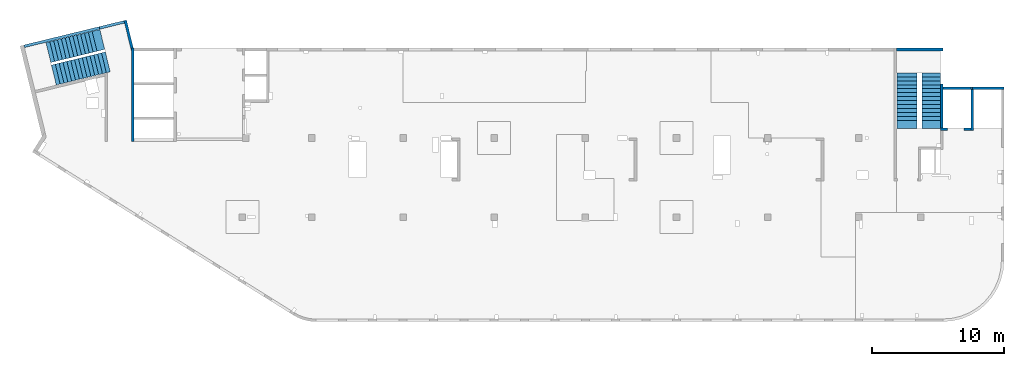
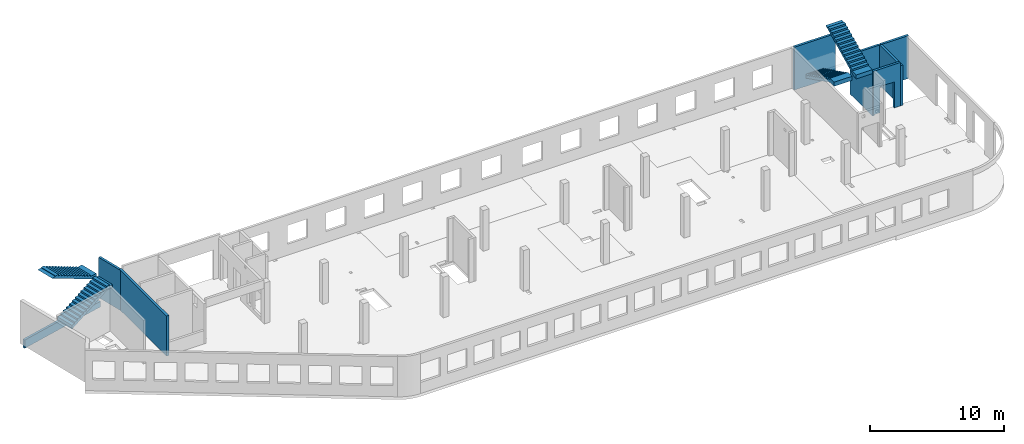
# One storey, part 3 of 6: 9 walls, 4 stairs, 3 openings.
"""IFC4 building model written with IfcOpenShell, lengths in millimetres."""

from ifc_helpers import new_model, entity, si_unit, converted_unit, derived_unit, direction, frame, origin, place, context, subcontext, project, spatial, indexed_curve, outline, extrude, polygons, material, type_object, element, save


model = new_model("IFC4")

# Units and contexts
model_context = context("Model", 3, precision=0.01, world=origin(), true_north=direction((6.12303176911189e-17, 1.0)))
plan_context = context("Plan", 3, precision=0.01, world=origin(), true_north=direction((6.12303176911189e-17, 1.0)))
body_context = subcontext(model_context, "Body", "Model", "MODEL_VIEW")
ifc_project = project(units=[si_unit("LENGTHUNIT", "METRE", prefix="MILLI"), si_unit("AREAUNIT", "SQUARE_METRE"), si_unit("VOLUMEUNIT", "CUBIC_METRE"), converted_unit("PLANEANGLEUNIT", "DEGREE", entity("IfcRatioMeasure", 0.0174532925199433), si_unit("PLANEANGLEUNIT", "RADIAN"), dimensions=[0, 0, 0, 0, 0, 0, 0]), si_unit("MASSUNIT", "GRAM", prefix="KILO"), derived_unit("MASSDENSITYUNIT", [(si_unit("MASSUNIT", "GRAM", prefix="KILO"), 1), (si_unit("LENGTHUNIT", "METRE"), -3)]), derived_unit("MOMENTOFINERTIAUNIT", [(si_unit("LENGTHUNIT", "METRE"), 4)]), si_unit("TIMEUNIT", "SECOND"), si_unit("FREQUENCYUNIT", "HERTZ"), si_unit("THERMODYNAMICTEMPERATUREUNIT", "DEGREE_CELSIUS"), derived_unit("THERMALTRANSMITTANCEUNIT", [(si_unit("MASSUNIT", "GRAM", prefix="KILO"), 1), (si_unit("THERMODYNAMICTEMPERATUREUNIT", "KELVIN"), -1), (si_unit("TIMEUNIT", "SECOND"), -3)]), derived_unit("VOLUMETRICFLOWRATEUNIT", [(si_unit("LENGTHUNIT", "METRE"), 3), (si_unit("TIMEUNIT", "SECOND"), -1)]), derived_unit("MASSFLOWRATEUNIT", [(si_unit("MASSUNIT", "GRAM", prefix="KILO"), 1), (si_unit("TIMEUNIT", "SECOND"), -1)]), derived_unit("ROTATIONALFREQUENCYUNIT", [(si_unit("TIMEUNIT", "SECOND"), -1)]), si_unit("ELECTRICCURRENTUNIT", "AMPERE"), si_unit("ELECTRICVOLTAGEUNIT", "VOLT"), si_unit("POWERUNIT", "WATT"), si_unit("FORCEUNIT", "NEWTON", prefix="KILO"), si_unit("ILLUMINANCEUNIT", "LUX"), si_unit("LUMINOUSFLUXUNIT", "LUMEN"), si_unit("LUMINOUSINTENSITYUNIT", "CANDELA"), derived_unit("USERDEFINED", [(si_unit("MASSUNIT", "GRAM", prefix="KILO"), -1), (si_unit("LENGTHUNIT", "METRE"), -2), (si_unit("TIMEUNIT", "SECOND"), 3), (si_unit("LUMINOUSFLUXUNIT", "LUMEN"), 1)]), derived_unit("LINEARVELOCITYUNIT", [(si_unit("LENGTHUNIT", "METRE"), 1), (si_unit("TIMEUNIT", "SECOND"), -1)]), si_unit("PRESSUREUNIT", "PASCAL"), derived_unit("USERDEFINED", [(si_unit("LENGTHUNIT", "METRE"), -2), (si_unit("MASSUNIT", "GRAM", prefix="KILO"), 1), (si_unit("TIMEUNIT", "SECOND"), -2)]), derived_unit("LINEARFORCEUNIT", [(si_unit("MASSUNIT", "GRAM", prefix="KILO"), 1), (si_unit("LENGTHUNIT", "METRE"), 1), (si_unit("TIMEUNIT", "SECOND"), -2), (si_unit("LENGTHUNIT", "METRE"), -1)]), derived_unit("PLANARFORCEUNIT", [(si_unit("MASSUNIT", "GRAM", prefix="KILO"), 1), (si_unit("LENGTHUNIT", "METRE"), 1), (si_unit("TIMEUNIT", "SECOND"), -2), (si_unit("LENGTHUNIT", "METRE"), -2)])], contexts=[model_context, plan_context])

# Site, building, storey
site_placement = place(None, origin())
site = spatial("IfcSite", under=ifc_project, at=site_placement, CompositionType="ELEMENT")
building_placement = place(site_placement, origin())
building = spatial("IfcBuilding", under=site, at=building_placement, CompositionType="ELEMENT")
storey_placement = place(building_placement, frame((0.0, 0.0, 8100.0)))
storey = spatial("IfcBuildingStorey", under=building, at=storey_placement, Name="03", CompositionType="ELEMENT", Elevation=8100.0)

# Walls
ifc_material_1 = material()
wall_type = type_object("IfcWallType", Name=":ADSK_ 25_200", PredefinedType="STANDARD")
wall_1_placement = place(storey_placement, frame((71070.0, 17470.0, -400.0)))
element("IfcWall", 1, at=wall_1_placement, inside=storey, type_object=wall_type, material=ifc_material_1, Name=":ADSK_ 25_200", ObjectType=":ADSK_ 25_200", PredefinedType="NOTDEFINED", context=body_context, shape_type="SweptSolid", body=[
    extrude(outline(indexed_curve([(2500.0008178711, -99.9999999999999), (2500.0008178711, 100.0), (99.9999999999943, 99.9999999999992), (99.9999999999949, -100.000000000001), (2500.0008178711, -99.9999999999999)], self_intersect=False)), origin(), (0.0, 0.0, 1.0), 3900.0),
])
wall_2_placement = place(storey_placement, frame((71170.0, 17370.0, -150.0), z_axis=(0.0, 0.0, 1.0), x_axis=(0.0, -1.0, 0.0)))
element("IfcWall", 2, at=wall_2_placement, inside=storey, type_object=wall_type, material=ifc_material_1, Name=":ADSK_ 25_200", ObjectType=":ADSK_ 25_200", PredefinedType="NOTDEFINED", context=body_context, shape_type="SweptSolid", body=[
    extrude(outline(indexed_curve([(3100.0, 100.000000000003), (-2.79449581754433e-13, 100.000000000003), (2.79449581754433e-13, -100.000000000003), (3100.0, -100.000000000003), (3100.0, 100.000000000003)], self_intersect=False)), origin(), (0.0, 0.0, 1.0), 3650.0),
])

# Wall, opening
wall_3_placement = place(storey_placement, frame((71070.0, 14370.0, -150.0), z_axis=(0.0, 0.0, 1.0), x_axis=(-1.0, 0.0, 0.0)))
wall_3 = element("IfcWall", 3, at=wall_3_placement, inside=storey, type_object=wall_type, material=ifc_material_1, Name=":ADSK_ 25_200", ObjectType=":ADSK_ 25_200", PredefinedType="NOTDEFINED", context=body_context, shape_type="Tessellation", body=[
    polygons([(2299.99918212887, -100.000000000003, 3950.0), (2099.99918212887, -100.000000000001, 3950.0), (-2.4387927500343e-12, -100.000000000001, 3950.0), (-2.4387927500343e-12, -100.000000000001, 0.0), (529.999182128873, -100.000000000001, 0.0), (529.999182128864, -100.000000000001, 2369.99999999805), (1769.99918212887, -99.9999999999989, 2369.99999999804), (1769.99918212887, -99.9999999999989, 0.0), (2299.99918212887, -100.000000000003, 0.0), (2299.99918212887, -100.000000000001, 3650.0), (-3.00376710535355e-12, 99.9999999999968, 3950.0), (2099.99918212887, 99.9999999999989, 3950.0), (2299.99918212887, 99.9999999999989, 3950.0), (2299.99918212887, 99.9999999999989, 3900.0), (2299.99918212887, 99.9999999999989, 0.0), (2099.99918212887, 99.9999999999989, 0.0), (1769.99918212887, 99.9999999999989, 0.0), (1769.99918212887, 99.9999999999989, 2369.99999999805), (529.999182128872, 99.9999999999989, 2369.99999999805), (529.999182128872, 99.9999999999989, 0.0), (-3.00376710535355e-12, 99.9999999999968, 0.0), (-3.00376710535355e-12, 99.9999999999989, 3650.0)], [[[1, 2, 3, 4, 5, 6, 7, 8, 9, 10]], [[11, 12, 13, 14, 15, 16, 17, 18, 19, 20, 21, 22]], [[4, 21, 20, 5]], [[3, 2, 1, 13, 12, 11]], [[4, 3, 11, 22, 21]], [[6, 19, 18, 7]], [[7, 18, 17, 8]], [[19, 6, 5, 20]], [[9, 15, 14, 13, 1, 10]], [[15, 9, 8, 17, 16]]], closed=True),
])
opening_1_placement = place(wall_3_placement, frame((71070.0, 14370.0, 150.0), z_axis=(0.0, 0.0, 1.0), x_axis=(-1.0, 0.0, 0.0)))
element("IfcOpeningElement", 4, at=opening_1_placement, cuts=wall_3, Name=":ADSK_ 25_200", PredefinedType="OPENING", context=body_context, shape_type="SweptSolid", body=[
    extrude(outline(indexed_curve([(-619.999999999998, -1184.99999999902), (620.000000000006, -1184.99999999902), (620.000000000006, 1184.99999999902), (-619.999999999998, 1184.99999999902), (-619.999999999998, -1184.99999999902)], self_intersect=False)), frame((69920.0, 14570.0, 1035.0), z_axis=(0.0, -1.0, 0.0), x_axis=(-1.0, 0.0, 0.0)), (0.0, 0.0, 1.0), 400.000000001943),
])

# Wall, openings
wall_4_placement = place(storey_placement, frame((7600.0, 20500.0, -150.0), z_axis=(0.0, 0.0, 1.0), x_axis=(0.0, -1.0, 0.0)))
wall_4 = element("IfcWall", 5, at=wall_4_placement, inside=storey, type_object=wall_type, material=ifc_material_1, Name=":ADSK_ 25_200", ObjectType=":ADSK_ 25_200", PredefinedType="NOTDEFINED", context=body_context, shape_type="Tessellation", body=[
    polygons([(0.0, -100.000000000001, 0.0), (226.50010582161, -99.9999999999996, 0.0), (7050.0006393668, -99.9999999999996, 0.0), (7050.0006393668, -99.9999999999996, 3650.0), (226.500105821614, -99.9999999999996, 3650.0), (0.0, -100.000000000001, 3650.0), (0.0, 100.0, 0.0), (0.0, 100.0, 3650.0), (200.000000000002, 100.0, 3650.0), (6850.0006393668, 100.0, 3650.0), (7050.0006393668, 99.9999999999993, 3650.0), (7050.0006393668, 100.0, 1200.0), (7050.0006393668, 99.9999999999993, 0.0), (6850.0006393668, 100.0, 0.0), (0.0, 50.6443876577722, 0.0), (0.0, 50.6443876577722, 3650.0), (0.0, 7.9044633377313e-14, 3650.0)], [[[1, 2, 3, 4, 5, 6]], [[7, 8, 9, 10, 11, 12, 13, 14]], [[3, 2, 1, 15, 7, 14, 13]], [[6, 5, 4, 11, 10, 9, 8, 16, 17]], [[1, 6, 17, 16, 8, 7, 15]], [[4, 3, 13, 12, 11]]], closed=True),
])
placement_1 = place(wall_4_placement, frame((20500.0, -7600.0, 150.0), z_axis=(0.0, 0.0, 1.0), x_axis=(0.0, 1.0, 0.0)))
element("IfcOpeningElement", 6, at=placement_1, cuts=wall_4, Name=":ADSK_ 25_200", PredefinedType="OPENING", context=body_context, shape_type="SweptSolid", body=[
    extrude(outline(indexed_curve([(-154.999999999993, -154.999999999999), (154.999999999993, -154.999999999999), (154.999999999993, 154.999999999999), (-154.999999999993, 154.999999999999), (-154.999999999993, -154.999999999999)], self_intersect=False)), frame((7500.0, 14360.0, 3655.0), z_axis=(1.0, 0.0, 0.0), x_axis=(0.0, 0.0, -1.0)), (0.0, 0.0, 1.0), 200.000000000962),
])
element("IfcOpeningElement", 7, at=placement_1, cuts=wall_4, Name=":ADSK_ 25_200", PredefinedType="OPENING", context=body_context, shape_type="SweptSolid", body=[
    extrude(outline(indexed_curve([(-154.999999999993, -154.999999999999), (154.999999999993, -154.999999999999), (154.999999999993, 154.999999999999), (-154.999999999993, 154.999999999999), (-154.999999999993, -154.999999999999)], self_intersect=False)), frame((7500.0, 14800.0, 3655.0), z_axis=(1.0, 0.0, 0.0), x_axis=(0.0, 0.0, -1.0)), (0.0, 0.0, 1.0), 200.000000000962),
])

# Walls
wall_5_placement = place(storey_placement, frame((68870.0, 17780.0, -400.0), z_axis=(0.0, 0.0, 1.0), x_axis=(0.0, -1.0, 0.0)))
element("IfcWall", 8, at=wall_5_placement, inside=storey, type_object=wall_type, material=ifc_material_1, Name=":ADSK_ 25_200", ObjectType=":ADSK_ 25_200", PredefinedType="NOTDEFINED", context=body_context, shape_type="Tessellation", body=[
    polygons([(2.16573425859679e-12, -99.9999999999946, 0.0), (3310.0, -99.9999999999946, 0.0), (3310.0, -99.9999999999946, 249.999999999999), (3310.0, -99.9999999999946, 3900.0), (2.16573425859679e-12, -99.9999999999946, 3900.0), (3310.0, 100.000000000012, 0.0), (410.0, 100.000000000003, 0.0), (210.0, 100.000000000003, 0.0), (2.16573425859679e-12, 100.000000000012, 0.0), (2.16573425859679e-12, 100.000000000012, 3900.0), (3310.0, 100.000000000012, 3900.0)], [[[1, 2, 3, 4, 5]], [[6, 7, 8, 9, 10, 11]], [[2, 1, 9, 8, 7, 6]], [[9, 1, 5, 10]], [[2, 6, 11, 4, 3]], [[5, 4, 11, 10]]], closed=True),
])
wall_6_placement = place(storey_placement, frame((68970.0, 17470.0, -400.0)))
element("IfcWall", 9, at=wall_6_placement, inside=storey, type_object=wall_type, material=ifc_material_1, Name=":ADSK_ 25_200", ObjectType=":ADSK_ 25_200", PredefinedType="NOTDEFINED", context=body_context, shape_type="Tessellation", body=[
    polygons([(6.89939203009021e-12, -100.000000000001, 0.0), (2199.99918212887, -100.000000000001, 0.0), (2199.99918212887, -100.000000000001, 249.999999999999), (2099.99918212888, -100.000000000001, 249.999999999999), (2099.99918212888, -100.000000000001, 3900.0), (6.89939203009021e-12, -100.000000000001, 3900.0), (2199.99918212887, 99.9999999999989, 0.0), (6.28061057235613e-12, 99.9999999999989, 0.0), (6.28061057235613e-12, 99.9999999999989, 3900.0), (2099.99918212888, 99.9999999999989, 3900.0), (2099.99918212888, 99.9999999999989, 249.999999999999), (2199.99918212887, 99.9999999999989, 249.999999999999)], [[[1, 2, 3, 4, 5, 6]], [[7, 8, 9, 10, 11, 12]], [[2, 1, 8, 7]], [[2, 7, 12, 3]], [[5, 4, 11, 10]], [[8, 1, 6, 9]], [[4, 3, 12, 11]], [[6, 5, 10, 9]]], closed=True),
])
wall_7_placement = place(storey_placement, frame((65430.0, 20400.0, -400.0)))
element("IfcWall", 10, at=wall_7_placement, inside=storey, type_object=wall_type, material=ifc_material_1, Name=":ADSK_ 25_200", ObjectType=":ADSK_ 25_200", PredefinedType="NOTDEFINED", context=body_context, shape_type="SweptSolid", body=[
    extrude(outline(indexed_curve([(3539.99999999995, 99.9999999999989), (-3.67073603151997e-13, 99.9999999999989), (3.67073603151997e-13, -99.9999999999989), (3539.99999999995, -99.9999999999989), (3539.99999999995, 99.9999999999989)], self_intersect=False)), origin(), (0.0, 0.0, 1.0), 3900.0),
])
wall_8_placement = place(storey_placement, frame((7033.44, 22609.75, -150.0), z_axis=(0.0, 0.0, 1.0), x_axis=(0.236826092990328, -0.971552058141475, 0.0)))
element("IfcWall", 11, at=wall_8_placement, inside=storey, type_object=wall_type, material=ifc_material_1, Name=":ADSK_ 25_200", ObjectType=":ADSK_ 25_200", PredefinedType="NOTDEFINED", context=body_context, shape_type="Tessellation", body=[
    polygons([(-4.33146851719357e-12, -99.9999999999989, 0.0), (2380.28371765147, -99.9999999999995, 0.0), (2380.28371765147, -100.000000000001, 3650.0), (199.999999999998, -100.0, 3650.0), (-4.33146851719357e-12, -99.9999999999989, 3650.0), (-4.33146851719357e-12, -99.9999999999989, 3150.0), (-4.33146851719357e-12, 100.0, 0.0), (-4.33146851719357e-12, 100.0, 3650.0), (2195.90359543113, 99.9999999999989, 3650.0), (2195.90359543113, 99.9999999999989, 0.0), (2160.22707367122, -46.3588648763722, 0.0), (2160.22707367122, -46.3588648763722, 3650.0)], [[[1, 2, 3, 4, 5, 6]], [[7, 8, 9, 10]], [[2, 1, 7, 10, 11]], [[11, 10, 9, 12]], [[1, 6, 5, 8, 7]], [[3, 2, 11, 12]], [[5, 4, 3, 12, 9, 8]]], closed=True),
])
wall_9_placement = place(storey_placement, frame((-618.13, 20641.67, -900.0), z_axis=(0.0, 0.0, 1.0), x_axis=(0.971552058141473, 0.236826092990338, 0.0)))
element("IfcWall", 12, at=wall_9_placement, inside=storey, type_object=wall_type, material=ifc_material_1, Name=":ADSK_ 25_200", ObjectType=":ADSK_ 25_200", PredefinedType="NOTDEFINED", context=body_context, shape_type="Tessellation", body=[
    polygons([(0.0, -100.000000000003, -1.08286712929839e-12), (7799.99206966279, -99.9999999999989, -1.08286712929839e-12), (7799.99206966279, -99.9999999999989, 500.000000000004), (5869.9920696628, -100.000000000003, 500.000000000004), (5869.99206966279, -100.000000000003, 750.000000000001), (5.41433564649196e-13, -100.000000000003, 750.000000000001), (7799.99206966279, 99.9999999999989, -1.08286712929839e-12), (1.08286712929839e-12, 99.9999999999989, -1.08286712929839e-12), (0.0, 99.9999999999989, 500.000000000001), (0.0, 99.9999999999989, 750.000000000001), (5869.9920696628, 99.9999999999989, 750.000000000001), (5869.9920696628, 99.9999999999989, 500.000000000004), (7799.99206966279, 99.9999999999989, 500.000000000004)], [[[1, 2, 3, 4, 5, 6]], [[7, 8, 9, 10, 11, 12, 13]], [[2, 1, 8, 7]], [[10, 6, 5, 11]], [[12, 4, 3, 13]], [[4, 12, 11, 5]], [[2, 7, 13, 3]], [[1, 6, 10, 9, 8]]], closed=True),
])

# Stairs
ifc_material_2 = material()
stair_type_1 = type_object("IfcStairType", Name="18: 15", PredefinedType="HALF_TURN_STAIR")
placement_2 = place(storey_placement, origin())
element("IfcStair", 13, at=placement_2, inside=storey, type_object=stair_type_1, material=ifc_material_2, Name="18: 15", ObjectType="18: 15", PredefinedType="HALF_TURN_STAIR", context=body_context, shape_type="SweptSolid", body=[
    extrude(outline(indexed_curve([(843.870967741944, -2179.17507067743), (1213.87096774194, -2179.17507067743), (1213.87096774195, -1871.96147517747), (-906.129032258053, 2368.03852482254), (-906.129032258053, 2020.82492932259), (-956.129032258054, 2020.82492932259), (-956.129032258054, 1720.82492932259), (-806.129032258056, 1720.82492932259), (-806.129032258056, 1420.82492932259), (-656.129032258055, 1420.82492932259), (-656.129032258055, 1120.82492932258), (-506.129032258057, 1120.82492932258), (-506.129032258057, 820.824929322583), (-356.129032258056, 820.824929322583), (-356.129032258056, 520.824929322582), (-206.129032258056, 520.824929322582), (-206.129032258056, 220.824929322581), (-56.1290322580552, 220.824929322581), (-56.1290322580552, -79.1750706774201), (93.8709677419453, -79.1750706774201), (93.8709677419453, -379.175070677421), (243.870967741946, -379.175070677421), (243.870967741946, -679.175070677422), (393.870967741944, -679.175070677422), (393.870967741944, -979.175070677423), (543.870967741945, -979.175070677423), (543.870967741945, -1279.17507067742), (693.870967741945, -1279.17507067742), (693.870967741945, -1579.17507067743), (843.870967741944, -1579.17507067743), (843.870967741944, -2179.17507067743)], self_intersect=False)), frame((67360.0, 16609.17, 4713.87), z_axis=(1.0, 0.0, 0.0), x_axis=(0.0, 0.0, -1.0)), (0.0, 0.0, 1.0), 1390.0),
])
stair_type_2 = type_object("IfcStairType", Name="24: 22", PredefinedType="HALF_TURN_STAIR")
element("IfcStair", 14, at=placement_2, inside=storey, type_object=stair_type_2, material=ifc_material_2, Name="24: 22", ObjectType="24: 22", PredefinedType="HALF_TURN_STAIR", context=body_context, shape_type="SweptSolid", body=[
    extrude(outline(indexed_curve([(-1961.8142397, -852.000000000003), (-1961.8142397, -1202.0), (-1914.60064420005, -1202.00000000001), (1645.39935579997, 577.999999999996), (2238.18576029999, 577.999999999996), (2238.18576029999, 947.999999999997), (1638.18576030001, 947.999999999997), (1638.18576030001, 797.999999999998), (1338.18576030001, 797.999999999998), (1338.18576030001, 647.999999999998), (1038.18576030001, 647.999999999998), (1038.18576030001, 497.999999999997), (738.185760300008, 497.999999999997), (738.185760300008, 347.999999999997), (438.185760300007, 347.999999999997), (438.185760300007, 197.999999999996), (138.185760300006, 197.999999999996), (138.185760300006, 47.9999999999977), (-161.814239699995, 47.9999999999977), (-161.814239699995, -102.000000000003), (-461.814239699997, -102.000000000003), (-461.814239699997, -252.000000000003), (-761.814239699998, -252.000000000003), (-761.814239699998, -402.000000000002), (-1061.8142397, -402.000000000002), (-1061.8142397, -552.000000000002), (-1361.8142397, -552.000000000002), (-1361.8142397, -702.000000000003), (-1661.8142397, -702.000000000003), (-1661.8142397, -852.000000000003), (-1961.8142397, -852.000000000003)], self_intersect=False)), frame((65450.0, 16668.18, 2922.0), z_axis=(-1.0, 0.0, 0.0), x_axis=(0.0, -1.0, 0.0)), (0.0, 0.0, -1.0), 1550.0),
])
stair_type_3 = type_object("IfcStairType", Name="31: 3", PredefinedType="HALF_TURN_STAIR")
element("IfcStair", 15, at=placement_2, inside=storey, type_object=stair_type_3, material=ifc_material_2, Name="31: 3", ObjectType="31: 3", PredefinedType="HALF_TURN_STAIR", context=body_context, shape_type="SweptSolid", body=[
    extrude(outline(indexed_curve([(871.999999999999, -2240.93152968505), (1242.0, -2240.93152968505), (1241.99999999999, -1934.66369491541), (-878.000000000013, 2305.33630508466), (-878.000000000014, 1958.12270958467), (-927.999999999998, 1958.12270958467), (-927.999999999997, 1658.12270958467), (-777.999999999997, 1658.12270958467), (-777.999999999998, 1358.12270958466), (-627.999999999998, 1358.12270958466), (-627.999999999997, 1058.12270958466), (-477.999999999998, 1058.12270958466), (-477.999999999997, 758.122709584654), (-327.999999999997, 758.122709584654), (-327.999999999998, 458.122709584651), (-177.999999999998, 458.12270958465), (-177.999999999999, 158.122709584646), (-27.9999999999984, 158.122709584646), (-27.9999999999997, -141.877290415355), (122.000000000001, -141.877290415355), (122.000000000002, -441.877290415358), (272.0, -441.877290415359), (272.000000000001, -741.877290415361), (421.999999999999, -741.877290415362), (422.0, -1041.87729041536), (572.000000000001, -1041.87729041537), (571.999999999999, -1341.87729041537), (722.0, -1341.87729041537), (721.999999999999, -1641.87729041537), (871.999999999999, -1641.87729041537), (871.999999999999, -2240.93152968505)], self_intersect=False)), frame((3302.28, 19878.41, 4742.0), z_axis=(-0.236826092990341, 0.971552058141472, 0.0), x_axis=(0.0, 0.0, -1.0)), (0.0, 0.0, 1.0), 1550.00000000006),
])
stair_type_4 = type_object("IfcStairType", Name="36: 34", PredefinedType="HALF_TURN_STAIR")
element("IfcStair", 16, at=placement_2, inside=storey, type_object=stair_type_4, material=ifc_material_2, Name="36: 34", ObjectType="36: 34", PredefinedType="HALF_TURN_STAIR", context=body_context, shape_type="SweptSolid", body=[
    extrude(outline(indexed_curve([(-2082.95035407268, -903.749999999996), (-2082.95035407268, -1253.75), (-2035.73675857273, -1253.75), (1524.26324142725, 526.24999999998), (2117.04171559009, 526.249999999978), (2117.0417155901, 776.249999999973), (1817.04964592736, 776.249999999975), (1817.04964592736, 896.250000000011), (1517.04964592735, 896.250000000011), (1517.04964592735, 746.25000000001), (1217.04964592735, 746.25000000001), (1217.04964592735, 596.250000000009), (917.049645927346, 596.250000000009), (917.049645927346, 446.250000000009), (617.049645927341, 446.250000000009), (617.049645927341, 296.250000000008), (317.049645927337, 296.250000000008), (317.049645927336, 146.250000000008), (17.0496459273321, 146.250000000008), (17.049645927331, -3.74999999999277), (-282.950354072672, -3.74999999999277), (-282.950354072672, -153.749999999993), (-582.950354072675, -153.749999999993), (-582.950354072676, -303.749999999994), (-882.950354072678, -303.749999999994), (-882.950354072679, -453.749999999994), (-1182.95035407268, -453.749999999994), (-1182.95035407268, -603.749999999995), (-1482.95035407268, -603.749999999995), (-1482.95035407268, -753.749999999996), (-1782.95035407268, -753.749999999996), (-1782.95035407268, -903.749999999996), (-2082.95035407268, -903.749999999996)], self_intersect=False)), frame((3838.0, 18207.76, 2973.75), z_axis=(0.236826092990333, -0.971552058141474, 0.0), x_axis=(0.971552058141474, 0.236826092990333, 0.0)), (0.0, 0.0, -1.0), 1550.0),
])

save(model, "model.ifc")
